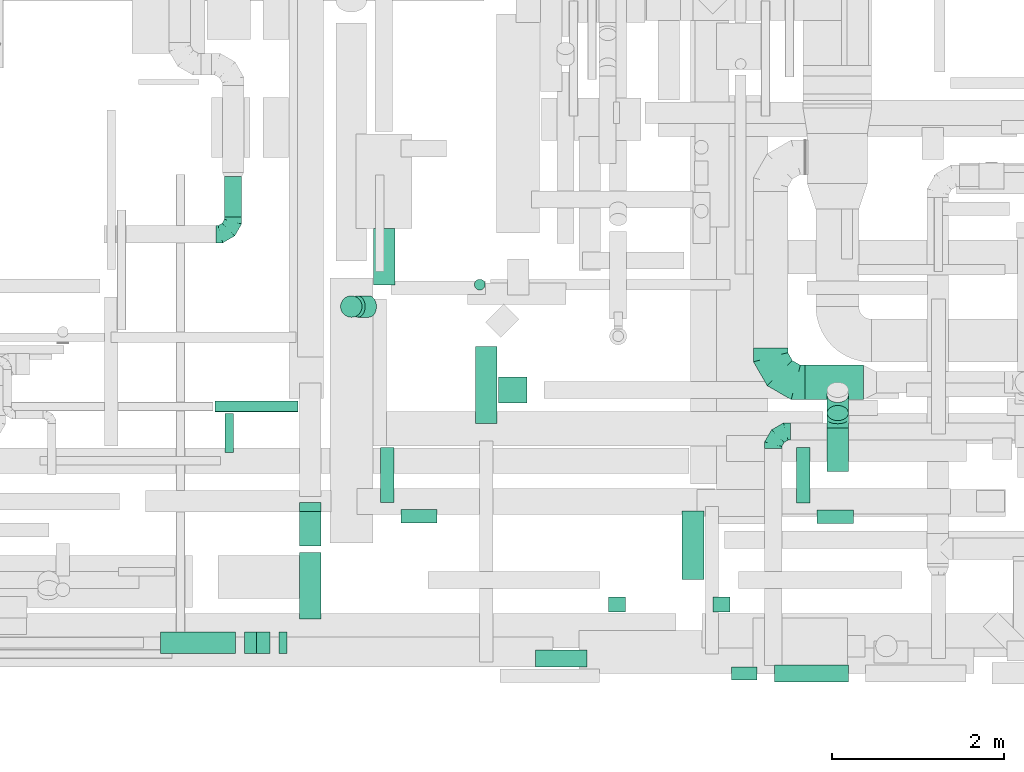
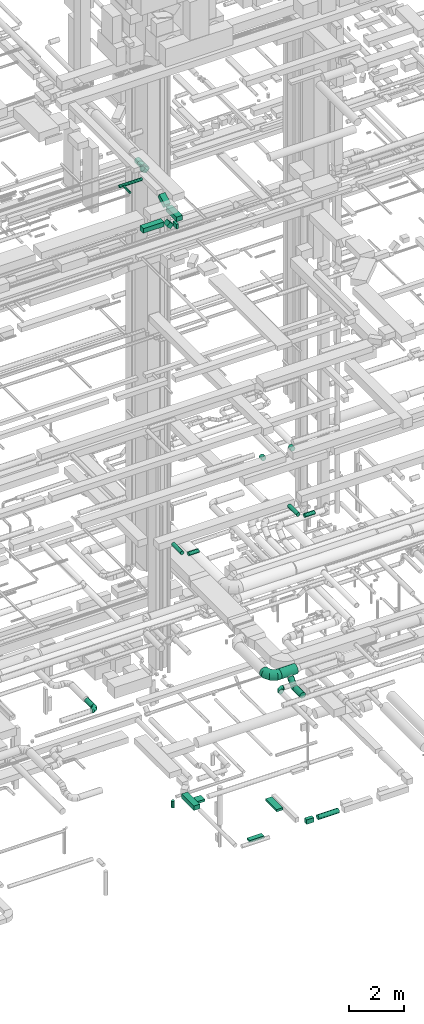
# One storey, part 159 of 337: 27 flow segments, 4 flow fittings.
"""IFC2X3 building model written with IfcOpenShell, lengths in millimetres."""

from ifc_helpers import new_model, entity, si_unit, converted_unit, derived_unit, direction, frame, frame_2d, origin, origin_2d_with_axis, place, context, subcontext, project, spatial, rectangle, circle, extrude, faceted_brep, source, transform, mapped, material, type_object, type_shapes, element, save


model = new_model("IFC2X3")

# Units and contexts
model_context = context("Model", 3, precision=0.01, world=origin(), true_north=direction((6.12303176911189e-17, 1.0)))
body_context = subcontext(model_context, "Body", "Model", "MODEL_VIEW")
ifc_project = project(units=[si_unit("LENGTHUNIT", "METRE", prefix="MILLI"), si_unit("AREAUNIT", "SQUARE_METRE"), si_unit("VOLUMEUNIT", "CUBIC_METRE"), converted_unit("PLANEANGLEUNIT", "DEGREE", entity("IfcRatioMeasure", 0.0174532925199433), si_unit("PLANEANGLEUNIT", "RADIAN"), dimensions=[0, 0, 0, 0, 0, 0, 0]), si_unit("MASSUNIT", "GRAM", prefix="KILO"), derived_unit("MASSDENSITYUNIT", [(si_unit("MASSUNIT", "GRAM", prefix="KILO"), 1), (si_unit("LENGTHUNIT", "METRE"), -3)]), derived_unit("MOMENTOFINERTIAUNIT", [(si_unit("LENGTHUNIT", "METRE"), 4)]), si_unit("TIMEUNIT", "SECOND"), si_unit("FREQUENCYUNIT", "HERTZ"), si_unit("THERMODYNAMICTEMPERATUREUNIT", "DEGREE_CELSIUS"), derived_unit("THERMALTRANSMITTANCEUNIT", [(si_unit("MASSUNIT", "GRAM", prefix="KILO"), 1), (si_unit("THERMODYNAMICTEMPERATUREUNIT", "KELVIN"), -1), (si_unit("TIMEUNIT", "SECOND"), -3)]), derived_unit("VOLUMETRICFLOWRATEUNIT", [(si_unit("LENGTHUNIT", "METRE"), 3), (si_unit("TIMEUNIT", "SECOND"), -1)]), derived_unit("MASSFLOWRATEUNIT", [(si_unit("MASSUNIT", "GRAM", prefix="KILO"), 1), (si_unit("TIMEUNIT", "SECOND"), -1)]), derived_unit("ROTATIONALFREQUENCYUNIT", [(si_unit("TIMEUNIT", "SECOND"), -1)]), si_unit("ELECTRICCURRENTUNIT", "AMPERE"), si_unit("ELECTRICVOLTAGEUNIT", "VOLT"), si_unit("POWERUNIT", "WATT"), si_unit("FORCEUNIT", "NEWTON", prefix="KILO"), si_unit("ILLUMINANCEUNIT", "LUX"), si_unit("LUMINOUSFLUXUNIT", "LUMEN"), si_unit("LUMINOUSINTENSITYUNIT", "CANDELA"), derived_unit("USERDEFINED", [(si_unit("MASSUNIT", "GRAM", prefix="KILO"), -1), (si_unit("LENGTHUNIT", "METRE"), -2), (si_unit("TIMEUNIT", "SECOND"), 3), (si_unit("LUMINOUSFLUXUNIT", "LUMEN"), 1)]), derived_unit("LINEARVELOCITYUNIT", [(si_unit("LENGTHUNIT", "METRE"), 1), (si_unit("TIMEUNIT", "SECOND"), -1)]), si_unit("PRESSUREUNIT", "PASCAL"), derived_unit("USERDEFINED", [(si_unit("LENGTHUNIT", "METRE"), -2), (si_unit("MASSUNIT", "GRAM", prefix="KILO"), 1), (si_unit("TIMEUNIT", "SECOND"), -2)]), derived_unit("LINEARFORCEUNIT", [(si_unit("MASSUNIT", "GRAM", prefix="KILO"), 1), (si_unit("LENGTHUNIT", "METRE"), 1), (si_unit("TIMEUNIT", "SECOND"), -2), (si_unit("LENGTHUNIT", "METRE"), -1)]), derived_unit("PLANARFORCEUNIT", [(si_unit("MASSUNIT", "GRAM", prefix="KILO"), 1), (si_unit("LENGTHUNIT", "METRE"), 1), (si_unit("TIMEUNIT", "SECOND"), -2), (si_unit("LENGTHUNIT", "METRE"), -2)])], contexts=[model_context])

# Site, building, storey
site_placement = place(None, origin())
site = spatial("IfcSite", under=ifc_project, at=site_placement, CompositionType="ELEMENT")
building_placement = place(site_placement, origin())
building = spatial("IfcBuilding", under=site, at=building_placement, CompositionType="ELEMENT")
storey_placement = place(building_placement, origin())
storey = spatial("IfcBuildingStorey", under=building, at=storey_placement, CompositionType="ELEMENT", Elevation=0.0)

# Flow segments
duct_segment_type_1 = type_object("IfcDuctSegmentType", PredefinedType="NOTDEFINED")
flow_segment_1_placement = place(storey_placement, frame((41964.6, 3181.98, -950.0)))
element("IfcFlowSegment", 1, at=flow_segment_1_placement, inside=storey, type_object=duct_segment_type_1, context=body_context, shape_type="SweptSolid", body=[
    extrude(rectangle(XDim=895.203349597387, YDim=250.000000000004, at=origin_2d_with_axis()), frame((125.0, 447.6, 0.0), z_axis=(0.0, 0.0, 1.0), x_axis=(0.0, -1.0, 0.0)), (0.0, 0.0, 1.0), 200.0),
])
flow_segment_2_placement = place(storey_placement, frame((42662.03, 348.86, -900.0)))
element("IfcFlowSegment", 2, at=flow_segment_2_placement, inside=storey, type_object=duct_segment_type_1, context=body_context, shape_type="SweptSolid", body=[
    extrude(rectangle(XDim=200.0, YDim=600.000000000002, at=origin_2d_with_axis()), frame((300.0, 100.0, 0.0), z_axis=(0.0, 0.0, 1.0), x_axis=(0.0, 1.0, 0.0)), (0.0, 0.0, 1.0), 100.0),
])
flow_segment_3_placement = place(storey_placement, frame((42234.6, 3423.53, -900.0)))
element("IfcFlowSegment", 3, at=flow_segment_3_placement, inside=storey, type_object=duct_segment_type_1, context=body_context, shape_type="SweptSolid", body=[
    extrude(rectangle(XDim=330.308660000007, YDim=300.0, at=origin_2d_with_axis()), frame((165.15, 150.0, 0.0)), (0.0, 0.0, 1.0), 100.0),
])
flow_segment_4_placement = place(storey_placement, frame((44943.59, 198.87, -800.0)))
element("IfcFlowSegment", 4, at=flow_segment_4_placement, inside=storey, type_object=duct_segment_type_1, context=body_context, shape_type="SweptSolid", body=[
    extrude(rectangle(XDim=300.204466499987, YDim=150.0, at=origin_2d_with_axis()), frame((150.1, 75.0, 0.0), z_axis=(0.0, 0.0, 1.0), x_axis=(-1.0, 0.0, 0.0)), (0.0, 0.0, 1.0), 200.0),
])
flow_segment_5_placement = place(storey_placement, frame((44368.59, 1366.12, -750.0)))
element("IfcFlowSegment", 5, at=flow_segment_5_placement, inside=storey, type_object=duct_segment_type_1, context=body_context, shape_type="SweptSolid", body=[
    extrude(rectangle(XDim=254.999966500009, YDim=800.0, at=origin_2d_with_axis()), frame((127.5, 400.0, 0.0), z_axis=(0.0, 0.0, 1.0), x_axis=(-1.0, 0.0, 0.0)), (0.0, 0.0, 1.0), 100.0),
])
flow_segment_6_placement = place(storey_placement, frame((38300.98, 505.67, 27450.0)))
element("IfcFlowSegment", 6, at=flow_segment_6_placement, inside=storey, type_object=duct_segment_type_1, context=body_context, shape_type="SweptSolid", body=[
    extrude(rectangle(XDim=869.856641074484, YDim=250.0, at=origin_2d_with_axis()), frame((434.93, 125.0, 0.0), z_axis=(0.0, 0.0, 1.0), x_axis=(-1.0, 0.0, 0.0)), (0.0, 0.0, 1.0), 199.999999999998),
])
flow_segment_7_placement = place(storey_placement, frame((39920.11, 905.67, 27150.0)))
element("IfcFlowSegment", 7, at=flow_segment_7_placement, inside=storey, type_object=duct_segment_type_1, context=body_context, shape_type="SweptSolid", body=[
    extrude(rectangle(XDim=776.397444850341, YDim=250.000000000004, at=origin_2d_with_axis()), frame((125.0, 388.2, 0.0), z_axis=(0.0, 0.0, 1.0), x_axis=(0.0, -1.0, 0.0)), (0.0, 0.0, 1.0), 199.999999999998),
])
flow_segment_8_placement = place(storey_placement, frame((39920.11, 1757.07, 27196.89)))
element("IfcFlowSegment", 8, at=flow_segment_8_placement, inside=storey, type_object=duct_segment_type_1, context=body_context, shape_type="SweptSolid", body=[
    extrude(rectangle(XDim=200.000000000001, YDim=466.025421897213, at=frame_2d((0.0, 0.0), x_axis=(0.0, 1.0))), frame((0.0, 251.79, 203.11), z_axis=(1.0, 0.0, 0.0), x_axis=(0.0, -0.866025410712622, -0.499999988000034)), (0.0, 0.0, 1.0), 249.999999999995),
])
flow_segment_9_placement = place(storey_placement, frame((39677.94, 505.67, 27150.0)))
element("IfcFlowSegment", 9, at=flow_segment_9_placement, inside=storey, type_object=duct_segment_type_1, context=body_context, shape_type="SweptSolid", body=[
    extrude(rectangle(XDim=92.166618206739, YDim=250.0, at=origin_2d_with_axis()), frame((46.08, 125.0, 0.0), z_axis=(0.0, 0.0, 1.0), x_axis=(-1.0, 0.0, 0.0)), (0.0, 0.0, 1.0), 199.999999999998),
])
flow_segment_10_placement = place(storey_placement, frame((39276.9, 505.67, 27252.51)))
element("IfcFlowSegment", 10, at=flow_segment_10_placement, inside=storey, type_object=duct_segment_type_1, context=body_context, shape_type="SweptSolid", body=[
    extrude(rectangle(XDim=217.157287525359, YDim=200.000000000001, at=origin_2d_with_axis()), frame((147.49, 0.0, 147.49), z_axis=(0.0, 1.0, 0.0), x_axis=(-0.707106781186488, 0.0, 0.707106781186607)), (0.0, 0.0, 1.0), 250.0),
])
duct_segment_type_2 = type_object("IfcDuctSegmentType", PredefinedType="NOTDEFINED")
flow_segment_11_placement = place(storey_placement, frame((45443.8, 172.28, -801.6)))
element("IfcFlowSegment", 11, at=flow_segment_11_placement, inside=storey, type_object=duct_segment_type_2, context=body_context, shape_type="SweptSolid", body=[
    extrude(circle(Radius=100.0, at=origin_2d_with_axis()), frame((0.0, 101.6, 101.6), z_axis=(1.0, 0.0, 0.0), x_axis=(0.0, 1.0, 0.0)), (0.0, 0.0, 1.0), 862.329403500012),
])
flow_segment_12_placement = place(storey_placement, frame((41951.22, 4734.54, -1797.99)))
element("IfcFlowSegment", 12, at=flow_segment_12_placement, inside=storey, type_object=duct_segment_type_2, context=body_context, shape_type="SweptSolid", body=[
    extrude(circle(Radius=62.5, at=origin_2d_with_axis()), frame((64.1, 64.1, 0.0), z_axis=(0.0, 0.0, 1.0), x_axis=(0.0, -1.0, 0.0)), (0.0, 0.0, 1.0), 292.989898732239),
])
for number, where in (
    (13, (41098.46, 2021.28, 11268.4)),
    (14, (45941.48, 2017.57, 11268.4)),
):
    element("IfcFlowSegment", number, at=place(storey_placement, frame(where)), inside=storey, type_object=duct_segment_type_2, context=body_context, shape_type="SweptSolid", body=[
        extrude(circle(Radius=80.0, at=origin_2d_with_axis()), frame((0.0, 81.6, 81.6), z_axis=(1.0, 0.0, 0.0), x_axis=(0.0, -1.0, 0.0)), (0.0, 0.0, 1.0), 420.000000000008),
    ])
flow_segment_13_placement = place(storey_placement, frame((40856.86, 2262.88, 11268.4)))
element("IfcFlowSegment", 15, at=flow_segment_13_placement, inside=storey, type_object=duct_segment_type_2, context=body_context, shape_type="SweptSolid", body=[
    extrude(circle(Radius=80.0, at=origin_2d_with_axis()), frame((81.6, 0.0, 81.6), z_axis=(0.0, 1.0, 0.0), x_axis=(-1.0, 0.0, 0.0)), (0.0, 0.0, 1.0), 640.000000000076),
])
flow_segment_14_placement = place(storey_placement, frame((45699.89, 2259.16, 11268.4)))
element("IfcFlowSegment", 16, at=flow_segment_14_placement, inside=storey, type_object=duct_segment_type_2, context=body_context, shape_type="SweptSolid", body=[
    extrude(circle(Radius=80.0, at=origin_2d_with_axis()), frame((81.6, 0.0, 81.6), z_axis=(0.0, 1.0, 0.0), x_axis=(-1.0, 0.0, 0.0)), (0.0, 0.0, 1.0), 643.712130818741),
])
flow_segment_15_placement = place(storey_placement, frame((39042.55, 5585.04, 3078.4)))
element("IfcFlowSegment", 17, at=flow_segment_15_placement, inside=storey, type_object=duct_segment_type_2, context=body_context, shape_type="SweptSolid", body=[
    extrude(circle(Radius=100.0, at=origin_2d_with_axis()), frame((101.6, 0.0, 101.6), z_axis=(0.0, 1.0, 0.0), x_axis=(-1.0, 0.0, 0.0)), (0.0, 0.0, 1.0), 470.000000000001),
])
flow_segment_16_placement = place(storey_placement, frame((43510.6, 990.66, 15248.4)))
element("IfcFlowSegment", 18, at=flow_segment_16_placement, inside=storey, type_object=duct_segment_type_2, context=body_context, shape_type="SweptSolid", body=[
    extrude(circle(Radius=100.0, at=origin_2d_with_axis()), frame((101.6, 0.0, 101.6), z_axis=(0.0, 1.0, 0.0), x_axis=(1.0, 0.0, 0.0)), (0.0, 0.0, 1.0), 171.742634045108),
])
flow_segment_17_placement = place(storey_placement, frame((44726.36, 990.66, 15248.4)))
element("IfcFlowSegment", 19, at=flow_segment_17_placement, inside=storey, type_object=duct_segment_type_2, context=body_context, shape_type="SweptSolid", body=[
    extrude(circle(Radius=100.0, at=origin_2d_with_axis()), frame((101.6, 0.0, 101.6), z_axis=(0.0, 1.0, 0.0), x_axis=(1.0, 0.0, 0.0)), (0.0, 0.0, 1.0), 171.742634045179),
])
flow_segment_18_placement = place(storey_placement, frame((38935.98, 3316.14, 27485.9)))
element("IfcFlowSegment", 20, at=flow_segment_18_placement, inside=storey, type_object=duct_segment_type_2, context=body_context, shape_type="SweptSolid", body=[
    extrude(circle(Radius=62.5, at=origin_2d_with_axis()), frame((0.0, 64.1, 64.1), z_axis=(1.0, 0.0, 0.0), x_axis=(0.0, 1.0, 0.0)), (0.0, 0.0, 1.0), 964.130040467769),
])
flow_segment_19_placement = place(storey_placement, frame((39048.16, 2847.74, 27498.4)))
element("IfcFlowSegment", 21, at=flow_segment_19_placement, inside=storey, type_object=duct_segment_type_2, context=body_context, shape_type="SweptSolid", body=[
    extrude(circle(Radius=50.0, at=origin_2d_with_axis()), frame((51.6, 0.0, 51.6), z_axis=(0.0, 1.0, 0.0), x_axis=(-1.0, 0.0, 0.0)), (0.0, 0.0, 1.0), 449.999999999977),
])
flow_segment_20_placement = place(storey_placement, frame((45799.84, 3459.65, 3248.4)))
element("IfcFlowSegment", 22, at=flow_segment_20_placement, inside=storey, type_object=duct_segment_type_2, context=body_context, shape_type="SweptSolid", body=[
    extrude(circle(Radius=200.0, at=origin_2d_with_axis()), frame((0.0, 201.6, 201.6), z_axis=(1.0, 0.0, 0.0), x_axis=(0.0, -1.0, 0.0)), (0.0, 0.0, 1.0), 680.000000000019),
])
flow_segment_21_placement = place(storey_placement, frame((46054.25, 3214.48, 2983.24)))
element("IfcFlowSegment", 23, at=flow_segment_21_placement, inside=storey, type_object=duct_segment_type_2, context=body_context, shape_type="SweptSolid", body=[
    extrude(circle(Radius=125.0, at=origin_2d_with_axis()), frame((126.6, 89.98, 89.98), z_axis=(0.0, 0.707106781186548, 0.707106781186547), x_axis=(-1.0, 0.0, 0.0)), (0.0, 0.0, 1.0), 299.20120341827),
])
flow_segment_22_placement = place(storey_placement, frame((46054.25, 2622.83, 2873.4)))
element("IfcFlowSegment", 24, at=flow_segment_22_placement, inside=storey, type_object=duct_segment_type_2, context=body_context, shape_type="SweptSolid", body=[
    extrude(circle(Radius=125.0, at=origin_2d_with_axis()), frame((126.6, 0.0, 126.6), z_axis=(0.0, 1.0, 0.0), x_axis=(-1.0, 0.0, 0.0)), (0.0, 0.0, 1.0), 504.852813742381),
])
flow_segment_23_placement = place(storey_placement, frame((40775.07, 4793.59, 26648.4)))
element("IfcFlowSegment", 25, at=flow_segment_23_placement, inside=storey, type_object=duct_segment_type_2, context=body_context, shape_type="SweptSolid", body=[
    extrude(circle(Radius=125.0, at=origin_2d_with_axis()), frame((126.6, 0.0, 126.6), z_axis=(0.0, 1.0, 0.0), x_axis=(1.0, 0.0, 0.0)), (0.0, 0.0, 1.0), 655.625385594097),
])
flow_segment_24_placement = place(storey_placement, frame((40503.86, 4416.99, 26861.79)))
element("IfcFlowSegment", 26, at=flow_segment_24_placement, inside=storey, type_object=duct_segment_type_2, context=body_context, shape_type="SweptSolid", body=[
    extrude(circle(Radius=125.0, at=origin_2d_with_axis()), frame((89.98, 126.6, 221.02), z_axis=(0.707106781186673, 0.0, -0.707106781186422), x_axis=(0.0, 1.0, 0.0)), (0.0, 0.0, 1.0), 185.311857505846),
])
flow_segment_25_placement = place(storey_placement, frame((40394.03, 4416.99, 27259.59)))
element("IfcFlowSegment", 27, at=flow_segment_25_placement, inside=storey, type_object=duct_segment_type_2, context=body_context, shape_type="SweptSolid", body=[
    extrude(circle(Radius=125.0, at=origin_2d_with_axis()), frame((126.6, 126.6, 0.0), z_axis=(0.0, 0.0, 1.0), x_axis=(-1.0, 0.0, 0.0)), (0.0, 0.0, 1.0), 70.4113383301285),
])

# Flow fittings
ifc_material = material()
duct_fitting_type_1 = type_object("IfcDuctFittingType", PredefinedType="NOTDEFINED", material=ifc_material)
shared_shape_1 = source(origin(), body_context, "Body", "Brep", [
    faceted_brep([(-200.0, 0.0, -100.0), (-200.0, -25.88, -96.59), (-200.0, -50.0, -86.6), (-200.0, -70.71, -70.71), (-200.0, -86.6, -50.0), (-200.0, -96.59, -25.88), (-200.0, -100.0, 0.0), (-200.0, -96.59, 25.88), (-200.0, -86.6, 50.0), (-200.0, -70.71, 70.71), (-200.0, -50.0, 86.6), (-200.0, -25.88, 96.59), (-200.0, 0.0, 100.0), (-200.0, 25.88, 96.59), (-200.0, 50.0, 86.6), (-200.0, 70.71, 70.71), (-200.0, 86.6, 50.0), (-200.0, 96.59, 25.88), (-200.0, 100.0, 0.0), (-200.0, 96.59, -25.88), (-200.0, 86.6, -50.0), (-200.0, 70.71, -70.71), (-200.0, 50.0, -86.6), (-200.0, 25.88, -96.59), (-153.35, 25.88, 96.59), (-159.81, 50.0, 86.6), (-146.41, 0.0, 100.0), (-165.36, 70.71, 70.71), (-172.29, 96.59, 25.88), (-173.21, 100.0, 0.0), (-169.62, 86.6, 50.0), (-169.62, 86.6, -50.0), (-165.36, 70.71, -70.71), (-172.29, 96.59, -25.88), (-153.35, 25.88, -96.59), (-146.41, 0.0, -100.0), (-159.81, 50.0, -86.6), (-139.48, -25.88, -96.59), (-133.01, -50.0, -86.6), (-127.46, -70.71, -70.71), (-123.21, -86.6, -50.0), (-120.53, -96.59, -25.88), (-119.62, -100.0, 0.0), (-120.53, -96.59, 25.88), (-123.21, -86.6, 50.0), (-127.46, -70.71, 70.71), (-133.01, -50.0, 86.6), (-139.48, -25.88, 96.59), (-72.54, 72.54, 96.59), (-90.19, 90.19, 86.6), (-53.59, 53.59, 100.0), (-105.35, 105.35, 70.71), (-116.99, 116.99, 50.0), (-124.3, 124.3, 25.88), (-126.79, 126.79, 0.0), (-124.3, 124.3, -25.88), (-116.99, 116.99, -50.0), (-105.35, 105.35, -70.71), (-72.54, 72.54, -96.59), (-53.59, 53.59, -100.0), (-90.19, 90.19, -86.6), (-34.64, 34.64, -96.59), (-16.99, 16.99, -86.6), (-1.83, 1.83, -70.71), (9.81, -9.81, -50.0), (17.12, -17.12, -25.88), (19.62, -19.62, 0.0), (17.12, -17.12, 25.88), (9.81, -9.81, 50.0), (-1.83, 1.83, 70.71), (-16.99, 16.99, 86.6), (-34.64, 34.64, 96.59), (-25.88, 153.35, 96.59), (-50.0, 159.81, 86.6), (0.0, 146.41, 100.0), (-70.71, 165.36, 70.71), (-86.6, 169.62, 50.0), (-96.59, 172.29, 25.88), (-100.0, 173.21, 0.0), (-96.59, 172.29, -25.88), (-86.6, 169.62, -50.0), (-70.71, 165.36, -70.71), (-25.88, 153.35, -96.59), (0.0, 146.41, -100.0), (-50.0, 159.81, -86.6), (25.88, 139.48, -96.59), (50.0, 133.01, -86.6), (70.71, 127.46, -70.71), (86.6, 123.21, -50.0), (96.59, 120.53, -25.88), (100.0, 119.62, 0.0), (96.59, 120.53, 25.88), (86.6, 123.21, 50.0), (70.71, 127.46, 70.71), (50.0, 133.01, 86.6), (25.88, 139.48, 96.59), (-25.88, 200.0, -96.59), (-50.0, 200.0, -86.6), (-70.71, 200.0, -70.71), (-86.6, 200.0, -50.0), (-96.59, 200.0, -25.88), (-100.0, 200.0, 0.0), (-96.59, 200.0, 25.88), (-86.6, 200.0, 50.0), (-70.71, 200.0, 70.71), (-50.0, 200.0, 86.6), (-25.88, 200.0, 96.59), (0.0, 200.0, 100.0), (25.88, 200.0, 96.59), (50.0, 200.0, 86.6), (70.71, 200.0, 70.71), (86.6, 200.0, 50.0), (96.59, 200.0, 25.88), (100.0, 200.0, 0.0), (96.59, 200.0, -25.88), (86.6, 200.0, -50.0), (70.71, 200.0, -70.71), (50.0, 200.0, -86.6), (25.88, 200.0, -96.59), (0.0, 200.0, -100.0)], [[[0, 1, 2, 3, 4, 5, 6, 7, 8, 9, 10, 11, 12, 13, 14, 15, 16, 17, 18, 19, 20, 21, 22, 23]], [[24, 25, 14, 13]], [[26, 24, 13, 12]], [[14, 25, 27, 15]], [[28, 29, 18, 17]], [[30, 28, 17, 16]], [[15, 27, 30, 16]], [[20, 31, 32, 21]], [[33, 31, 20, 19]], [[18, 29, 33, 19]], [[34, 35, 0, 23]], [[36, 34, 23, 22]], [[32, 36, 22, 21]], [[1, 0, 35, 37]], [[2, 1, 37, 38]], [[38, 39, 3, 2]], [[5, 4, 40, 41]], [[6, 5, 41, 42]], [[39, 40, 4, 3]], [[6, 42, 43, 7]], [[7, 43, 44, 8]], [[8, 44, 45, 9]], [[9, 45, 46, 10]], [[10, 46, 47, 11]], [[26, 12, 11, 47]], [[48, 49, 25, 24]], [[50, 48, 24, 26]], [[27, 25, 49, 51]], [[52, 53, 28, 30]], [[51, 52, 30, 27]], [[29, 28, 53, 54]], [[55, 56, 31, 33]], [[54, 55, 33, 29]], [[32, 31, 56, 57]], [[58, 59, 35, 34]], [[60, 58, 34, 36]], [[57, 60, 36, 32]], [[37, 35, 59, 61]], [[38, 37, 61, 62]], [[39, 38, 62, 63]], [[41, 40, 64, 65]], [[42, 41, 65, 66]], [[63, 64, 40, 39]], [[43, 42, 66, 67]], [[44, 43, 67, 68]], [[68, 69, 45, 44]], [[46, 45, 69, 70]], [[47, 46, 70, 71]], [[26, 47, 71, 50]], [[72, 73, 49, 48]], [[74, 72, 48, 50]], [[51, 49, 73, 75]], [[76, 77, 53, 52]], [[75, 76, 52, 51]], [[54, 53, 77, 78]], [[79, 80, 56, 55]], [[78, 79, 55, 54]], [[57, 56, 80, 81]], [[82, 83, 59, 58]], [[84, 82, 58, 60]], [[81, 84, 60, 57]], [[61, 59, 83, 85]], [[62, 61, 85, 86]], [[63, 62, 86, 87]], [[65, 64, 88, 89]], [[66, 65, 89, 90]], [[87, 88, 64, 63]], [[67, 66, 90, 91]], [[68, 67, 91, 92]], [[92, 93, 69, 68]], [[70, 69, 93, 94]], [[71, 70, 94, 95]], [[50, 71, 95, 74]], [[96, 97, 98, 99, 100, 101, 102, 103, 104, 105, 106, 107, 108, 109, 110, 111, 112, 113, 114, 115, 116, 117, 118, 119]], [[72, 74, 107, 106]], [[73, 72, 106, 105]], [[75, 73, 105, 104]], [[102, 101, 78, 77]], [[103, 102, 77, 76]], [[75, 104, 103, 76]], [[78, 101, 100, 79]], [[79, 100, 99, 80]], [[80, 99, 98, 81]], [[84, 97, 96, 82]], [[82, 96, 119, 83]], [[84, 81, 98, 97]], [[118, 117, 86, 85]], [[119, 118, 85, 83]], [[116, 87, 86, 117]], [[88, 115, 114, 89]], [[89, 114, 113, 90]], [[115, 88, 87, 116]], [[91, 90, 113, 112]], [[92, 91, 112, 111]], [[111, 110, 93, 92]], [[95, 94, 109, 108]], [[74, 95, 108, 107]], [[110, 109, 94, 93]]]),
])
type_shapes(duct_fitting_type_1, [shared_shape_1])
flow_fitting_1_placement = place(storey_placement, frame((39144.14, 5385.04, 3180.0)))
element("IfcFlowFitting", 28, at=flow_fitting_1_placement, inside=storey, type_object=duct_fitting_type_1, material=ifc_material, context=body_context, shape_type="MappedRepresentation", body=[
    mapped(shared_shape_1, transform((0.0, 0.0, 0.0), scale=1.0)),
])
flow_fitting_2_placement = place(storey_placement, frame((45429.84, 3089.11, 3250.0), z_axis=(0.0, 0.0, 1.0), x_axis=(-1.0, 0.0, 0.0)))
element("IfcFlowFitting", 29, at=flow_fitting_2_placement, inside=storey, type_object=duct_fitting_type_1, material=ifc_material, context=body_context, shape_type="MappedRepresentation", body=[
    mapped(shared_shape_1, transform((0.0, 0.0, 0.0), scale=1.0)),
])
duct_fitting_type_2 = type_object("IfcDuctFittingType", PredefinedType="NOTDEFINED", material=ifc_material)
shared_shape_2 = source(origin(), body_context, "Body", "Brep", [
    faceted_brep([(-400.0, 0.0, -200.0), (-400.0, -44.5, -194.99), (-400.0, -86.78, -180.19), (-400.0, -124.7, -156.37), (-400.0, -156.37, -124.7), (-400.0, -180.19, -86.78), (-400.0, -194.99, -44.5), (-400.0, -200.0, 0.0), (-400.0, -194.99, 44.5), (-400.0, -180.19, 86.78), (-400.0, -156.37, 124.7), (-400.0, -124.7, 156.37), (-400.0, -86.78, 180.19), (-400.0, -44.5, 194.99), (-400.0, 0.0, 200.0), (-400.0, 44.5, 194.99), (-400.0, 86.78, 180.19), (-400.0, 124.7, 156.37), (-400.0, 156.37, 124.7), (-400.0, 180.19, 86.78), (-400.0, 194.99, 44.5), (-400.0, 200.0, 0.0), (-400.0, 194.99, -44.5), (-400.0, 180.19, -86.78), (-400.0, 156.37, -124.7), (-400.0, 124.7, -156.37), (-400.0, 86.78, -180.19), (-400.0, 44.5, -194.99), (-292.82, 0.0, 200.0), (-304.75, 44.5, 194.99), (-316.07, 86.78, 180.19), (-326.23, 124.7, 156.37), (-334.72, 156.37, 124.7), (-341.1, 180.19, 86.78), (-345.07, 194.99, 44.5), (-346.41, 200.0, 0.0), (-345.07, 194.99, -44.5), (-341.1, 180.19, -86.78), (-334.72, 156.37, -124.7), (-326.23, 124.7, -156.37), (-316.07, 86.78, -180.19), (-304.75, 44.5, -194.99), (-292.82, 0.0, -200.0), (-280.9, -44.5, -194.99), (-269.57, -86.78, -180.19), (-259.41, -124.7, -156.37), (-250.92, -156.37, -124.7), (-244.54, -180.19, -86.78), (-240.57, -194.99, -44.5), (-239.23, -200.0, 0.0), (-240.57, -194.99, 44.5), (-244.54, -180.19, 86.78), (-250.92, -156.37, 124.7), (-259.41, -124.7, 156.37), (-269.57, -86.78, 180.19), (-280.9, -44.5, 194.99), (-107.18, 107.18, 200.0), (-139.76, 139.76, 194.99), (-170.7, 170.7, 180.19), (-198.46, 198.46, 156.37), (-221.65, 221.65, 124.7), (-239.09, 239.09, 86.78), (-249.92, 249.92, 44.5), (-253.59, 253.59, 0.0), (-249.92, 249.92, -44.5), (-239.09, 239.09, -86.78), (-221.65, 221.65, -124.7), (-198.46, 198.46, -156.37), (-170.7, 170.7, -180.19), (-139.76, 139.76, -194.99), (-107.18, 107.18, -200.0), (-74.6, 74.6, -194.99), (-43.65, 43.65, -180.19), (-15.89, 15.89, -156.37), (7.29, -7.29, -124.7), (24.73, -24.73, -86.78), (35.56, -35.56, -44.5), (39.23, -39.23, 0.0), (35.56, -35.56, 44.5), (24.73, -24.73, 86.78), (7.29, -7.29, 124.7), (-15.89, 15.89, 156.37), (-43.65, 43.65, 180.19), (-74.6, 74.6, 194.99), (0.0, 292.82, 200.0), (-44.5, 304.75, 194.99), (-86.78, 316.07, 180.19), (-124.7, 326.23, 156.37), (-156.37, 334.72, 124.7), (-180.19, 341.1, 86.78), (-194.99, 345.07, 44.5), (-200.0, 346.41, 0.0), (-194.99, 345.07, -44.5), (-180.19, 341.1, -86.78), (-156.37, 334.72, -124.7), (-124.7, 326.23, -156.37), (-86.78, 316.07, -180.19), (-44.5, 304.75, -194.99), (0.0, 292.82, -200.0), (44.5, 280.9, -194.99), (86.78, 269.57, -180.19), (124.7, 259.41, -156.37), (156.37, 250.92, -124.7), (180.19, 244.54, -86.78), (194.99, 240.57, -44.5), (200.0, 239.23, 0.0), (194.99, 240.57, 44.5), (180.19, 244.54, 86.78), (156.37, 250.92, 124.7), (124.7, 259.41, 156.37), (86.78, 269.57, 180.19), (44.5, 280.9, 194.99), (-44.5, 400.0, -194.99), (-86.78, 400.0, -180.19), (-124.7, 400.0, -156.37), (-156.37, 400.0, -124.7), (-180.19, 400.0, -86.78), (-194.99, 400.0, -44.5), (-200.0, 400.0, 0.0), (-194.99, 400.0, 44.5), (-180.19, 400.0, 86.78), (-156.37, 400.0, 124.7), (-124.7, 400.0, 156.37), (-86.78, 400.0, 180.19), (-44.5, 400.0, 194.99), (0.0, 400.0, 200.0), (44.5, 400.0, 194.99), (86.78, 400.0, 180.19), (124.7, 400.0, 156.37), (156.37, 400.0, 124.7), (180.19, 400.0, 86.78), (194.99, 400.0, 44.5), (200.0, 400.0, 0.0), (194.99, 400.0, -44.5), (180.19, 400.0, -86.78), (156.37, 400.0, -124.7), (124.7, 400.0, -156.37), (86.78, 400.0, -180.19), (44.5, 400.0, -194.99), (0.0, 400.0, -200.0)], [[[0, 1, 2, 3, 4, 5, 6, 7, 8, 9, 10, 11, 12, 13, 14, 15, 16, 17, 18, 19, 20, 21, 22, 23, 24, 25, 26, 27]], [[28, 29, 15, 14]], [[30, 31, 17, 16]], [[29, 30, 16, 15]], [[31, 32, 18, 17]], [[32, 33, 19, 18]], [[34, 35, 21, 20]], [[33, 34, 20, 19]], [[35, 36, 22, 21]], [[37, 38, 24, 23]], [[36, 37, 23, 22]], [[38, 39, 25, 24]], [[39, 40, 26, 25]], [[41, 42, 0, 27]], [[40, 41, 27, 26]], [[1, 0, 42, 43]], [[43, 44, 2, 1]], [[45, 3, 2, 44]], [[45, 46, 4, 3]], [[5, 4, 46, 47]], [[47, 48, 6, 5]], [[49, 7, 6, 48]], [[7, 49, 50, 8]], [[8, 50, 51, 9]], [[9, 51, 52, 10]], [[52, 53, 11, 10]], [[11, 53, 54, 12]], [[12, 54, 55, 13]], [[13, 55, 28, 14]], [[56, 57, 29, 28]], [[58, 59, 31, 30]], [[57, 58, 30, 29]], [[59, 60, 32, 31]], [[60, 61, 33, 32]], [[62, 63, 35, 34]], [[61, 62, 34, 33]], [[63, 64, 36, 35]], [[65, 66, 38, 37]], [[64, 65, 37, 36]], [[66, 67, 39, 38]], [[67, 68, 40, 39]], [[69, 70, 42, 41]], [[68, 69, 41, 40]], [[43, 42, 70, 71]], [[71, 72, 44, 43]], [[73, 45, 44, 72]], [[73, 74, 46, 45]], [[47, 46, 74, 75]], [[75, 76, 48, 47]], [[77, 49, 48, 76]], [[50, 49, 77, 78]], [[51, 50, 78, 79]], [[52, 51, 79, 80]], [[80, 81, 53, 52]], [[54, 53, 81, 82]], [[55, 54, 82, 83]], [[28, 55, 83, 56]], [[84, 85, 57, 56]], [[86, 87, 59, 58]], [[85, 86, 58, 57]], [[87, 88, 60, 59]], [[88, 89, 61, 60]], [[90, 91, 63, 62]], [[89, 90, 62, 61]], [[91, 92, 64, 63]], [[93, 94, 66, 65]], [[92, 93, 65, 64]], [[94, 95, 67, 66]], [[95, 96, 68, 67]], [[97, 98, 70, 69]], [[96, 97, 69, 68]], [[71, 70, 98, 99]], [[99, 100, 72, 71]], [[101, 73, 72, 100]], [[101, 102, 74, 73]], [[75, 74, 102, 103]], [[103, 104, 76, 75]], [[105, 77, 76, 104]], [[78, 77, 105, 106]], [[79, 78, 106, 107]], [[80, 79, 107, 108]], [[108, 109, 81, 80]], [[82, 81, 109, 110]], [[83, 82, 110, 111]], [[56, 83, 111, 84]], [[112, 113, 114, 115, 116, 117, 118, 119, 120, 121, 122, 123, 124, 125, 126, 127, 128, 129, 130, 131, 132, 133, 134, 135, 136, 137, 138, 139]], [[85, 84, 125, 124]], [[86, 85, 124, 123]], [[87, 86, 123, 122]], [[122, 121, 88, 87]], [[89, 88, 121, 120]], [[90, 89, 120, 119]], [[91, 90, 119, 118]], [[91, 118, 117, 92]], [[92, 117, 116, 93]], [[93, 116, 115, 94]], [[115, 114, 95, 94]], [[95, 114, 113, 96]], [[96, 113, 112, 97]], [[97, 112, 139, 98]], [[98, 139, 138, 99]], [[99, 138, 137, 100]], [[100, 137, 136, 101]], [[136, 135, 102, 101]], [[102, 135, 134, 103]], [[103, 134, 133, 104]], [[104, 133, 132, 105]], [[106, 105, 132, 131]], [[107, 106, 131, 130]], [[108, 107, 130, 129]], [[129, 128, 109, 108]], [[110, 109, 128, 127]], [[111, 110, 127, 126]], [[84, 111, 126, 125]]]),
])
type_shapes(duct_fitting_type_2, [shared_shape_2])
flow_fitting_3_placement = place(storey_placement, frame((45399.84, 3661.24, 3450.0), z_axis=(0.0, 0.0, 1.0), x_axis=(0.0, -1.0, 0.0)))
element("IfcFlowFitting", 30, at=flow_fitting_3_placement, inside=storey, type_object=duct_fitting_type_2, material=ifc_material, context=body_context, shape_type="MappedRepresentation", body=[
    mapped(shared_shape_2, transform((0.0, 0.0, 0.0), scale=1.0)),
])
duct_fitting_type_3 = type_object("IfcDuctFittingType", PredefinedType="NOTDEFINED", material=ifc_material)
shared_shape_3 = source(origin(), body_context, "Body", "Brep", [
    faceted_brep([(-103.55, 0.0, -125.0), (-103.55, -32.35, -120.74), (-103.55, -62.5, -108.25), (-103.55, -88.39, -88.39), (-103.55, -108.25, -62.5), (-103.55, -120.74, -32.35), (-103.55, -125.0, 0.0), (-103.55, -120.74, 32.35), (-103.55, -108.25, 62.5), (-103.55, -88.39, 88.39), (-103.55, -62.5, 108.25), (-103.55, -32.35, 120.74), (-103.55, 0.0, 125.0), (-103.55, 32.35, 120.74), (-103.55, 62.5, 108.25), (-103.55, 88.39, 88.39), (-103.55, 108.25, 62.5), (-103.55, 120.74, 32.35), (-103.55, 125.0, 0.0), (-103.55, 120.74, -32.35), (-103.55, 108.25, -62.5), (-103.55, 88.39, -88.39), (-103.55, 62.5, -108.25), (-103.55, 32.35, -120.74), (-13.4, 32.35, 120.74), (-25.89, 62.5, 108.25), (0.0, 0.0, 125.0), (-36.61, 88.39, 88.39), (-44.84, 108.25, 62.5), (-50.01, 120.74, 32.35), (-51.78, 125.0, 0.0), (-50.01, 120.74, -32.35), (-44.84, 108.25, -62.5), (-36.61, 88.39, -88.39), (-13.4, 32.35, -120.74), (0.0, 0.0, -125.0), (-25.89, 62.5, -108.25), (13.4, -32.35, -120.74), (25.89, -62.5, -108.25), (36.61, -88.39, -88.39), (44.84, -108.25, -62.5), (50.01, -120.74, -32.35), (51.78, -125.0, 0.0), (50.01, -120.74, 32.35), (44.84, -108.25, 62.5), (36.61, -88.39, 88.39), (25.89, -62.5, 108.25), (13.4, -32.35, 120.74), (73.22, 73.22, 125.0), (50.35, 96.1, 120.74), (29.03, 117.42, 108.25), (10.72, 135.72, 88.39), (-3.32, 149.77, 62.5), (-12.15, 158.6, 32.35), (-15.17, 161.61, 0.0), (-12.15, 158.6, -32.35), (-3.32, 149.77, -62.5), (10.72, 135.72, -88.39), (29.03, 117.42, -108.25), (50.35, 96.1, -120.74), (73.22, 73.22, -125.0), (96.1, 50.35, -120.74), (117.42, 29.03, -108.25), (135.72, 10.72, -88.39), (149.77, -3.32, -62.5), (158.6, -12.15, -32.35), (161.61, -15.17, 0.0), (158.6, -12.15, 32.35), (149.77, -3.32, 62.5), (135.72, 10.72, 88.39), (117.42, 29.03, 108.25), (96.1, 50.35, 120.74)], [[[0, 1, 2, 3, 4, 5, 6, 7, 8, 9, 10, 11, 12, 13, 14, 15, 16, 17, 18, 19, 20, 21, 22, 23]], [[24, 25, 14, 13]], [[26, 24, 13, 12]], [[14, 25, 27, 15]], [[28, 29, 17, 16]], [[28, 16, 15, 27]], [[30, 18, 17, 29]], [[31, 32, 20, 19]], [[30, 31, 19, 18]], [[32, 33, 21, 20]], [[34, 35, 0, 23]], [[36, 34, 23, 22]], [[33, 36, 22, 21]], [[1, 0, 35, 37]], [[2, 1, 37, 38]], [[38, 39, 3, 2]], [[5, 4, 40, 41]], [[6, 5, 41, 42]], [[39, 40, 4, 3]], [[6, 42, 43, 7]], [[7, 43, 44, 8]], [[8, 44, 45, 9]], [[9, 45, 46, 10]], [[10, 46, 47, 11]], [[26, 12, 11, 47]], [[24, 26, 48, 49]], [[25, 24, 49, 50]], [[27, 25, 50, 51]], [[29, 28, 52, 53]], [[30, 29, 53, 54]], [[51, 52, 28, 27]], [[30, 54, 55, 31]], [[31, 55, 56, 32]], [[57, 33, 32, 56]], [[36, 58, 59, 34]], [[34, 59, 60, 35]], [[58, 36, 33, 57]], [[35, 60, 61, 37]], [[37, 61, 62, 38]], [[63, 39, 38, 62]], [[40, 64, 65, 41]], [[41, 65, 66, 42]], [[64, 40, 39, 63]], [[43, 42, 66, 67]], [[44, 43, 67, 68]], [[68, 69, 45, 44]], [[47, 46, 70, 71]], [[26, 47, 71, 48]], [[69, 70, 46, 45]], [[59, 58, 57, 56, 55, 54, 53, 52, 51, 50, 49, 48, 71, 70, 69, 68, 67, 66, 65, 64, 63, 62, 61, 60]]]),
])
type_shapes(duct_fitting_type_3, [shared_shape_3])
flow_fitting_4_placement = place(storey_placement, frame((46180.84, 3231.24, 3000.0), z_axis=(-1.0, 0.0, 0.0), x_axis=(0.0, -0.707106781186545, -0.70710678118655)))
element("IfcFlowFitting", 31, at=flow_fitting_4_placement, inside=storey, type_object=duct_fitting_type_3, material=ifc_material, context=body_context, shape_type="MappedRepresentation", body=[
    mapped(shared_shape_3, transform((0.0, 0.0, 0.0), scale=1.0)),
])

save(model, "model.ifc")
